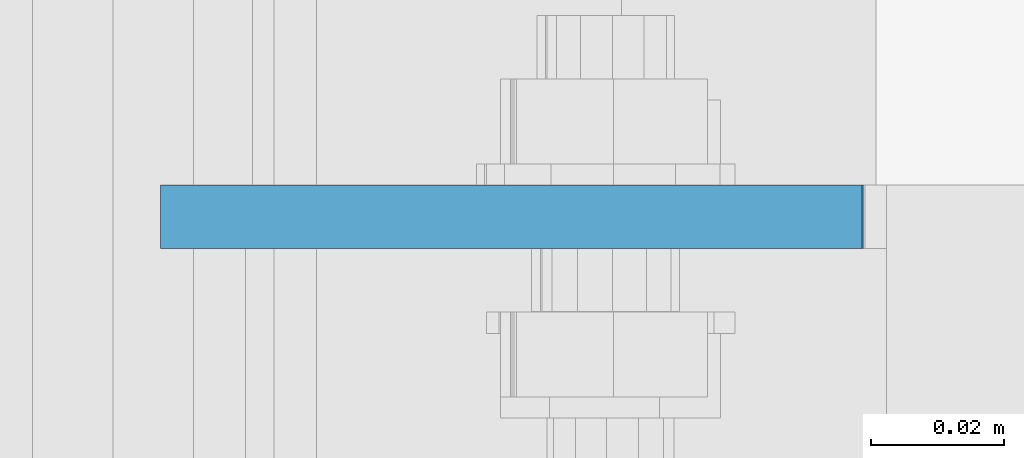
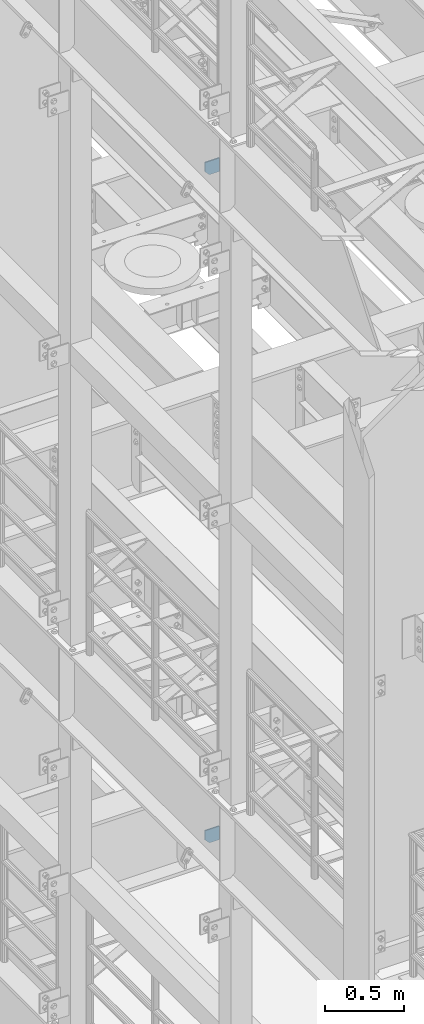
# One storey, part 1485 of 1876: 2 plates, 2 elements without a shape of their own.
"""IFC2X3 building model written with IfcOpenShell, lengths in millimetres."""

from ifc_helpers import new_model, si_unit, frame, origin_with_axes, place, context, subcontext, project, spatial, faceted_brep, material, type_object, element, aggregate, save


model = new_model("IFC2X3")

# Units and contexts
model_context = context("Model", 3, precision=1e-05, world=origin_with_axes())
body_context = subcontext(model_context, "Body", "Model", "MODEL_VIEW")
ifc_project = project(units=[si_unit("LENGTHUNIT", "METRE", prefix="MILLI"), si_unit("AREAUNIT", "SQUARE_METRE"), si_unit("VOLUMEUNIT", "CUBIC_METRE"), si_unit("MASSUNIT", "GRAM", prefix="KILO"), si_unit("TIMEUNIT", "SECOND"), si_unit("PLANEANGLEUNIT", "RADIAN"), si_unit("SOLIDANGLEUNIT", "STERADIAN"), si_unit("THERMODYNAMICTEMPERATUREUNIT", "DEGREE_CELSIUS"), si_unit("LUMINOUSINTENSITYUNIT", "LUMEN")], contexts=[model_context])

# Site, building, storey
site_placement = place(None, origin_with_axes())
site = spatial("IfcSite", under=ifc_project, at=site_placement, CompositionType="ELEMENT")
building_placement = place(site_placement, origin_with_axes())
building = spatial("IfcBuilding", under=site, at=building_placement, Name="Undefined", CompositionType="ELEMENT")
storey_placement = place(building_placement, origin_with_axes())
storey = spatial("IfcBuildingStorey", under=building, at=storey_placement, Name="Undefined", CompositionType="ELEMENT", Elevation=0.0)

# Assembly, plate
assembly_1_placement = place(storey_placement, origin_with_axes())
assembly_1 = element("IfcElementAssembly", 1, at=assembly_1_placement, inside=storey, Name="BEAM", AssemblyPlace="NOTDEFINED", PredefinedType="RIGID_FRAME")
ifc_material = material(Name="STEEL/A36")
plate_type_1 = type_object("IfcPlateType", PredefinedType="NOTDEFINED")
plate_1_placement = place(assembly_1_placement, frame((7.14374663738151, -2138.3625, 12816.9742795602), z_axis=(0.0, 0.0, -1.0), x_axis=(1.0, 0.0, 0.0)))
plate_1 = element("IfcPlate", 2, at=plate_1_placement, type_object=plate_type_1, material=ifc_material, Name="PLATE", context=body_context, shape_type="Brep", body=[
    faceted_brep([(0.0, -4.76249999999982, 0.0), (3.36263383360347e-06, -4.76249999999999, 72.5242767333984), (3.36263383360347e-06, 4.76249999999999, 72.5242767333984), (0.0, 4.76249999999982, 0.0), (31.7500038146972, -4.76249999999999, 104.274276733398), (31.7500038146972, 4.76249999999999, 104.274276733398), (105.092643737793, -4.76249999999999, 104.274276733398), (105.092643737793, 4.76249999999999, 104.274276733398), (105.092643737793, -4.76249999999999, 0.0), (105.092643737793, 4.76249999999999, 0.0)], [[[0, 1, 2, 3]], [[1, 4, 5, 2]], [[4, 6, 7, 5]], [[6, 8, 9, 7]], [[8, 0, 3, 9]], [[5, 7, 9, 3, 2]], [[8, 6, 4, 1, 0]]]),
])
aggregate(assembly_1, [plate_1])

assembly_2_placement = place(storey_placement, origin_with_axes())
assembly_2 = element("IfcElementAssembly", 3, at=assembly_2_placement, inside=storey, Name="BEAM", AssemblyPlace="NOTDEFINED", PredefinedType="RIGID_FRAME")
plate_type_2 = type_object("IfcPlateType", PredefinedType="NOTDEFINED")
plate_2_placement = place(assembly_2_placement, frame((7.14375, -2138.3625, 7556.5), z_axis=(0.0, 0.0, 1.0), x_axis=(1.0, 0.0, 0.0)))
plate_2 = element("IfcPlate", 4, at=plate_2_placement, type_object=plate_type_2, material=ifc_material, Name="PLATE", context=body_context, shape_type="Brep", body=[
    faceted_brep([(-9.76996261670138e-14, -4.76250000000073, 31.75), (0.0, -4.76249999999999, 103.486999511719), (0.0, 4.76249999999999, 103.486999511719), (-9.76996261670138e-14, 4.76250000000073, 31.75), (105.307250976562, -4.76249999999982, 103.486999511719), (105.307250976562, 4.76249999999982, 103.486999511719), (105.307250976562, -4.76249999999999, 0.0), (105.307250976562, 4.76249999999999, 0.0), (31.75, -4.76250000000073, 0.0), (31.75, 4.76250000000073, 0.0)], [[[0, 1, 2, 3]], [[1, 4, 5, 2]], [[4, 6, 7, 5]], [[6, 8, 9, 7]], [[8, 0, 3, 9]], [[5, 7, 9, 3, 2]], [[8, 6, 4, 1, 0]]]),
])
aggregate(assembly_2, [plate_2])

save(model, "model.ifc")
